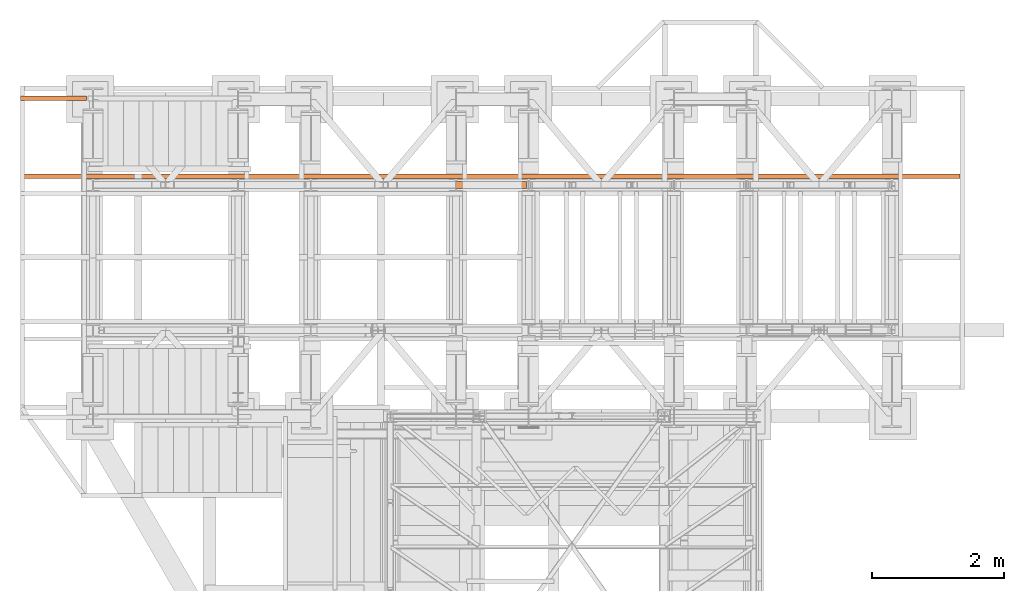
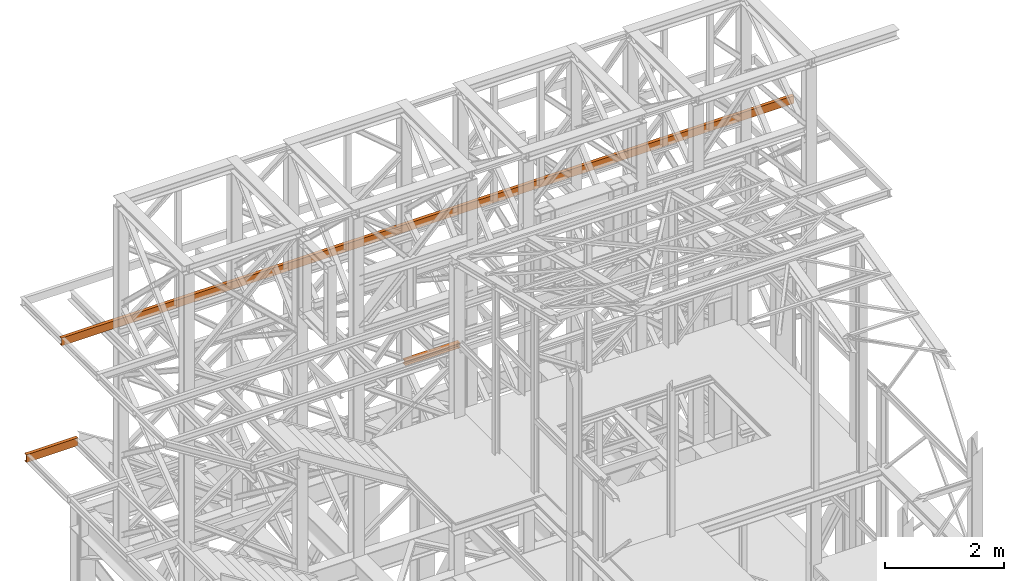
# One storey, part 131 of 208: 3 proxies.
"""IFC2X3 building model written with IfcOpenShell, lengths in millimetres."""

from ifc_helpers import new_model, entity, si_unit, converted_unit, frame, origin, origin_with_axes, place, context, subcontext, project, spatial, faceted_brep, element, save


model = new_model("IFC2X3")

# Units and contexts
model_context = context("Model", 3, precision=1e-05, world=origin())
plan_context = context("Plan", 3, precision=1e-05, world=origin())
body_context = subcontext(model_context, "Body", "Model", "MODEL_VIEW")
ifc_project = project(units=[si_unit("LENGTHUNIT", "METRE", prefix="MILLI"), converted_unit("PLANEANGLEUNIT", "DEGREE", entity("IfcPlaneAngleMeasure", 0.0174532925199433), si_unit("PLANEANGLEUNIT", "RADIAN"), dimensions=[0, 0, 0, 0, 0, 0, 0]), si_unit("AREAUNIT", "SQUARE_METRE"), si_unit("VOLUMEUNIT", "CUBIC_METRE")], contexts=[model_context, plan_context])

# Building, storey
building_placement = place(None, origin())
building = spatial("IfcBuilding", under=ifc_project, at=building_placement, CompositionType="COMPLEX")
storey_placement = place(building_placement, origin_with_axes())
storey = spatial("IfcBuildingStorey", under=building, at=storey_placement, Name="Geschoss", CompositionType="ELEMENT")

# Proxies
proxy_1_placement = place(storey_placement, frame((2191.525620187632, -13812.50587051042, 7070.668125081063), z_axis=(0.0, 0.0, 1.0), x_axis=(1.0, 0.0, 0.0)))
element("IfcBuildingElementProxy", 1, at=proxy_1_placement, inside=storey, context=body_context, shape_type="Brep", body=[
    faceted_brep([(1072.594465339767, 0.01000000000021828, 88.01000000000022), (1072.594465339767, 0.01000000000021828, 96.01000000000022), (1072.594465339767, 100.0100000000002, 96.01000000000022), (1072.594465339767, 100.0100000000002, 88.01000000000022), (1072.594465339767, 52.51000000000022, 88.01000000000022), (1072.594465339767, 52.51000000000022, 8.010000000000218), (1072.594465339767, 100.0100000000002, 8.010000000000218), (1072.594465339767, 100.0100000000002, 0.01000000000021828), (1072.594465339767, 0.01000000000021828, 0.01000000000021828), (1072.594465339767, 0.01000000000021828, 8.010000000000218), (1072.594465339767, 47.51000000000022, 8.010000000000218), (1072.594465339767, 47.51000000000022, 88.01000000000022), (1072.594465339767, 0.01000000000021828, 96.01000000000022), (1072.594465339767, 0.01000000000021828, 88.01000000000022), (0.009999999999763531, 0.01000000000385626, 88.01000000000022), (0.009999999999763531, 0.01000000000385626, 96.01000000000022), (1072.594465339767, 100.0100000000002, 96.01000000000022), (1072.594465339767, 0.01000000000021828, 96.01000000000022), (0.009999999999763531, 0.01000000000385626, 96.01000000000022), (0.009999999999763531, 100.0100000000039, 96.01000000000022), (1072.594465339767, 100.0100000000002, 88.01000000000022), (1072.594465339767, 100.0100000000002, 96.01000000000022), (0.009999999999763531, 100.0100000000039, 96.01000000000022), (0.009999999999763531, 100.0100000000039, 88.01000000000022), (1072.594465339767, 52.51000000000022, 88.01000000000022), (1072.594465339767, 100.0100000000002, 88.01000000000022), (0.009999999999763531, 100.0100000000039, 88.01000000000022), (0.009999999999763531, 52.51000000000386, 88.01000000000022), (1072.594465339767, 52.51000000000022, 8.010000000000218), (1072.594465339767, 52.51000000000022, 88.01000000000022), (0.009999999999763531, 52.51000000000386, 88.01000000000022), (0.009999999999763531, 52.51000000000386, 8.010000000000218), (1072.594465339767, 100.0100000000002, 8.010000000000218), (1072.594465339767, 52.51000000000022, 8.010000000000218), (0.009999999999763531, 52.51000000000386, 8.010000000000218), (0.009999999999763531, 100.0100000000039, 8.010000000000218), (1072.594465339767, 100.0100000000002, 0.01000000000021828), (1072.594465339767, 100.0100000000002, 8.010000000000218), (0.009999999999763531, 100.0100000000039, 8.010000000000218), (0.009999999999763531, 100.0100000000039, 0.01000000000021828), (1072.594465339767, 0.01000000000021828, 0.01000000000021828), (1072.594465339767, 100.0100000000002, 0.01000000000021828), (0.009999999999763531, 100.0100000000039, 0.01000000000021828), (0.009999999999763531, 0.01000000000385626, 0.01000000000021828), (1072.594465339767, 0.01000000000021828, 8.010000000000218), (1072.594465339767, 0.01000000000021828, 0.01000000000021828), (0.009999999999763531, 0.01000000000385626, 0.01000000000021828), (0.009999999999763531, 0.01000000000385626, 8.010000000000218), (1072.594465339767, 47.51000000000022, 8.010000000000218), (1072.594465339767, 0.01000000000021828, 8.010000000000218), (0.009999999999763531, 0.01000000000385626, 8.010000000000218), (0.009999999999763531, 47.51000000000386, 8.010000000000218), (1072.594465339767, 47.51000000000022, 88.01000000000022), (1072.594465339767, 47.51000000000022, 8.010000000000218), (0.009999999999763531, 47.51000000000386, 8.010000000000218), (0.009999999999763531, 47.51000000000386, 88.01000000000022), (1072.594465339767, 0.01000000000021828, 88.01000000000022), (1072.594465339767, 47.51000000000022, 88.01000000000022), (0.009999999999763531, 47.51000000000386, 88.01000000000022), (0.009999999999763531, 0.01000000000385626, 88.01000000000022), (0.009999999999763531, 0.01000000000385626, 88.01000000000022), (0.009999999999763531, 47.51000000000386, 88.01000000000022), (0.009999999999763531, 47.51000000000386, 8.010000000000218), (0.009999999999763531, 0.01000000000385626, 8.010000000000218), (0.009999999999763531, 0.01000000000385626, 0.01000000000021828), (0.009999999999763531, 100.0100000000039, 0.01000000000021828), (0.009999999999763531, 100.0100000000039, 8.010000000000218), (0.009999999999763531, 52.51000000000386, 8.010000000000218), (0.009999999999763531, 52.51000000000386, 88.01000000000022), (0.009999999999763531, 100.0100000000039, 88.01000000000022), (0.009999999999763531, 100.0100000000039, 96.01000000000022), (0.009999999999763531, 0.01000000000385626, 96.01000000000022)], [[[0, 1, 2, 3, 4, 5, 6, 7, 8, 9, 10, 11]], [[12, 13, 14, 15]], [[16, 17, 18, 19]], [[20, 21, 22, 23]], [[24, 25, 26, 27]], [[28, 29, 30, 31]], [[32, 33, 34, 35]], [[36, 37, 38, 39]], [[40, 41, 42, 43]], [[44, 45, 46, 47]], [[48, 49, 50, 51]], [[52, 53, 54, 55]], [[56, 57, 58, 59]], [[60, 61, 62, 63, 64, 65, 66, 67, 68, 69, 70, 71]]], orient=[[False], [False], [False], [False], [False], [False], [False], [False], [False], [False], [False], [False], [False], [False]]),
])
proxy_2_placement = place(storey_placement, frame((-4406.745032961459, -13662.57438882777, 9699.99), z_axis=(0.0, 0.0, 1.0), x_axis=(1.0, 0.0, 0.0)))
element("IfcBuildingElementProxy", 2, at=proxy_2_placement, inside=storey, context=body_context, shape_type="Brep", body=[
    faceted_brep([(0.01000000000021828, 65.01000000000022, 0.01000000000021828), (14234.76726640307, 65.01000000000022, 0.01000000000021828), (14234.76726640307, 65.01000000000022, 3.132428070246533), (0.01000000000021828, 65.01000000000022, 3.132428070246533), (0.01000000000021828, 65.01000000000022, 3.132428070246533), (14234.76726640307, 65.01000000000022, 3.132428070246533), (14234.76726640307, 64.76726342282745, 4.748288908171162), (0.01000000000021828, 64.76726342282745, 4.748288908171162), (0.01000000000021828, 64.76726342282745, 4.748288908171162), (14234.76726640307, 64.76726342282745, 4.748288908171162), (14234.76726640307, 64.06053228585552, 6.221534443444398), (0.01000000000021828, 64.06053228585733, 6.221534443444398), (0.01000000000021828, 64.06053228585733, 6.221534443444398), (14234.76726640307, 64.06053228585552, 6.221534443444398), (14234.76726640307, 62.95215163846842, 7.422126703873801), (0.01000000000021828, 62.95215163847024, 7.422126703873801), (0.01000000000021828, 62.95215163847024, 7.422126703873801), (14234.76726640307, 62.95215163846842, 7.422126703873801), (14234.76726640307, 61.53995641148504, 8.244091391710754), (0.01000000000021828, 61.53995641148686, 8.244091391710754), (0.01000000000021828, 61.53995641148686, 8.244091391710754), (14234.76726640307, 61.53995641148504, 8.244091391710754), (14234.76726640307, 59.9485987225562, 8.614912102195376), (0.01000000000021828, 59.94859872255802, 8.614912102195376), (0.01000000000021828, 59.94859872255802, 8.614912102195376), (14234.76726640307, 59.9485987225562, 8.614912102195376), (14234.76726640307, 17.17267516602988, 12.0369859867169), (0.01000000000021828, 17.17267516602988, 12.0369859867169), (0.01000000000021828, 17.17267516602988, 12.0369859867169), (14234.76726640307, 17.17267516602988, 12.0369859867169), (14234.76726640307, 14.13462866898408, 12.74491643400506), (0.01000000000021828, 14.1346286689859, 12.74491643400506), (0.01000000000021828, 14.1346286689859, 12.74491643400506), (14234.76726640307, 14.13462866898408, 12.74491643400506), (14234.76726640307, 11.43861959928654, 14.31412174714933), (0.01000000000021828, 11.43861959928836, 14.31412174714933), (0.01000000000021828, 11.43861959928836, 14.31412174714933), (14234.76726640307, 11.43861959928654, 14.31412174714933), (14234.76726640307, 9.322620181546881, 16.60616151705835), (0.01000000000021828, 9.3226201815487, 16.60616151705835), (0.01000000000021828, 9.3226201815487, 16.60616151705835), (14234.76726640307, 9.322620181546881, 16.60616151705835), (14234.76726640307, 7.97340619278657, 19.41872117530875), (0.01000000000021828, 7.97340619278657, 19.41872117530875), (0.01000000000021828, 7.97340619278657, 19.41872117530875), (14234.76726640307, 7.97340619278657, 19.41872117530875), (14234.76726640307, 7.510000000000218, 22.50354641134618), (0.01000000000021828, 7.510000000000218, 22.50354641134618), (0.01000000000021828, 7.510000000000218, 22.50354641134618), (14234.76726640307, 7.510000000000218, 22.50354641134618), (14234.76726640307, 7.510000000000218, 137.5164535886524), (0.01000000000021828, 7.510000000000218, 137.5164535886524), (0.01000000000021828, 7.510000000000218, 137.5164535886524), (14234.76726640307, 7.510000000000218, 137.5164535886524), (14234.76726640307, 7.97340619278657, 140.6012788246917), (0.01000000000021828, 7.97340619278657, 140.6012788246917), (0.01000000000021828, 7.97340619278657, 140.6012788246917), (14234.76726640307, 7.97340619278657, 140.6012788246917), (14234.76726640307, 9.322620181546881, 143.4138384829403), (0.01000000000021828, 9.3226201815487, 143.4138384829403), (0.01000000000021828, 9.3226201815487, 143.4138384829403), (14234.76726640307, 9.322620181546881, 143.4138384829403), (14234.76726640307, 11.43861959928654, 145.7058782528493), (0.01000000000021828, 11.43861959928836, 145.7058782528493), (0.01000000000021828, 11.43861959928836, 145.7058782528493), (14234.76726640307, 11.43861959928654, 145.7058782528493), (14234.76726640307, 14.13462866898408, 147.2750835659936), (0.01000000000021828, 14.1346286689859, 147.2750835659936), (0.01000000000021828, 14.1346286689859, 147.2750835659936), (14234.76726640307, 14.13462866898408, 147.2750835659936), (14234.76726640307, 17.17267516602988, 147.9830140132817), (0.01000000000021828, 17.17267516602988, 147.9830140132817), (0.01000000000021828, 17.17267516602988, 147.9830140132817), (14234.76726640307, 17.17267516602988, 147.9830140132817), (14234.76726640307, 59.9485987225562, 151.4050878978032), (0.01000000000021828, 59.94859872255802, 151.4050878978032), (0.01000000000021828, 59.94859872255802, 151.4050878978032), (14234.76726640307, 59.9485987225562, 151.4050878978032), (14234.76726640307, 61.53995641148504, 151.7759086082879), (0.01000000000021828, 61.53995641148686, 151.7759086082879), (0.01000000000021828, 61.53995641148686, 151.7759086082879), (14234.76726640307, 61.53995641148504, 151.7759086082879), (14234.76726640307, 62.95215163846842, 152.5978732961248), (0.01000000000021828, 62.95215163847024, 152.5978732961248), (0.01000000000021828, 62.95215163847024, 152.5978732961248), (14234.76726640307, 62.95215163846842, 152.5978732961248), (14234.76726640307, 64.06053228585552, 153.7984655565542), (0.01000000000021828, 64.06053228585733, 153.7984655565542), (0.01000000000021828, 64.06053228585733, 153.7984655565542), (14234.76726640307, 64.06053228585552, 153.7984655565542), (14234.76726640307, 64.76726342282745, 155.2717110918275), (0.01000000000021828, 64.76726342282745, 155.2717110918275), (0.01000000000021828, 64.76726342282745, 155.2717110918275), (14234.76726640307, 64.76726342282745, 155.2717110918275), (14234.76726640307, 65.01000000000022, 156.8875719297521), (0.01000000000021828, 65.01000000000022, 156.8875719297521), (0.01000000000021828, 65.01000000000022, 156.8875719297521), (14234.76726640307, 65.01000000000022, 156.8875719297521), (14234.76726640307, 65.01000000000022, 160.0100000000002), (0.01000000000021828, 65.01000000000022, 160.0100000000002), (0.01000000000021828, 65.01000000000022, 160.0100000000002), (14234.76726640307, 65.01000000000022, 160.0100000000002), (14234.76726640307, 0.01000000000021828, 160.0100000000002), (0.01000000000021828, 0.01000000000021828, 160.0100000000002), (0.01000000000021828, 0.01000000000021828, 160.0100000000002), (14234.76726640307, 0.01000000000021828, 160.0100000000002), (14234.76726640307, 0.01000000000021828, 0.01000000000021828), (0.01000000000021828, 0.01000000000021828, 0.01000000000021828), (0.01000000000021828, 0.01000000000021828, 0.01000000000021828), (14234.76726640307, 0.01000000000021828, 0.01000000000021828), (14234.76726640307, 65.01000000000022, 0.01000000000021828), (0.01000000000021828, 65.01000000000022, 0.01000000000021828), (0.01000000000021828, 65.01000000000022, 0.01000000000021828), (0.01000000000021828, 65.01000000000022, 3.132428070246533), (0.01000000000021828, 64.76726342282745, 4.748288908171162), (0.01000000000021828, 64.06053228585733, 6.221534443444398), (0.01000000000021828, 62.95215163847024, 7.422126703873801), (0.01000000000021828, 61.53995641148686, 8.244091391710754), (0.01000000000021828, 59.94859872255802, 8.614912102195376), (0.01000000000021828, 17.17267516602988, 12.0369859867169), (0.01000000000021828, 14.1346286689859, 12.74491643400506), (0.01000000000021828, 11.43861959928836, 14.31412174714933), (0.01000000000021828, 9.3226201815487, 16.60616151705835), (0.01000000000021828, 7.97340619278657, 19.41872117530875), (0.01000000000021828, 7.510000000000218, 22.50354641134618), (0.01000000000021828, 7.510000000000218, 137.5164535886524), (0.01000000000021828, 7.97340619278657, 140.6012788246917), (0.01000000000021828, 9.3226201815487, 143.4138384829403), (0.01000000000021828, 11.43861959928836, 145.7058782528493), (0.01000000000021828, 14.1346286689859, 147.2750835659936), (0.01000000000021828, 17.17267516602988, 147.9830140132817), (0.01000000000021828, 59.94859872255802, 151.4050878978032), (0.01000000000021828, 61.53995641148686, 151.7759086082879), (0.01000000000021828, 62.95215163847024, 152.5978732961248), (0.01000000000021828, 64.06053228585733, 153.7984655565542), (0.01000000000021828, 64.76726342282745, 155.2717110918275), (0.01000000000021828, 65.01000000000022, 156.8875719297521), (0.01000000000021828, 65.01000000000022, 160.0100000000002), (0.01000000000021828, 0.01000000000021828, 160.0100000000002), (0.01000000000021828, 0.01000000000021828, 0.01000000000021828), (14234.76726640307, 65.01000000000022, 0.01000000000021828), (14234.76726640307, 0.01000000000021828, 0.01000000000021828), (14234.76726640307, 0.01000000000021828, 160.0100000000002), (14234.76726640307, 65.01000000000022, 160.0100000000002), (14234.76726640307, 65.01000000000022, 156.8875719297521), (14234.76726640307, 64.76726342282745, 155.2717110918275), (14234.76726640307, 64.06053228585552, 153.7984655565542), (14234.76726640307, 62.95215163846842, 152.5978732961248), (14234.76726640307, 61.53995641148504, 151.7759086082879), (14234.76726640307, 59.9485987225562, 151.4050878978032), (14234.76726640307, 17.17267516602988, 147.9830140132817), (14234.76726640307, 14.13462866898408, 147.2750835659936), (14234.76726640307, 11.43861959928654, 145.7058782528493), (14234.76726640307, 9.322620181546881, 143.4138384829403), (14234.76726640307, 7.97340619278657, 140.6012788246917), (14234.76726640307, 7.510000000000218, 137.5164535886524), (14234.76726640307, 7.510000000000218, 22.50354641134618), (14234.76726640307, 7.97340619278657, 19.41872117530875), (14234.76726640307, 9.322620181546881, 16.60616151705835), (14234.76726640307, 11.43861959928654, 14.31412174714933), (14234.76726640307, 14.13462866898408, 12.74491643400506), (14234.76726640307, 17.17267516602988, 12.0369859867169), (14234.76726640307, 59.9485987225562, 8.614912102195376), (14234.76726640307, 61.53995641148504, 8.244091391710754), (14234.76726640307, 62.95215163846842, 7.422126703873801), (14234.76726640307, 64.06053228585552, 6.221534443444398), (14234.76726640307, 64.76726342282745, 4.748288908171162), (14234.76726640307, 65.01000000000022, 3.132428070246533)], [[[0, 1, 2, 3]], [[4, 5, 6, 7]], [[8, 9, 10, 11]], [[12, 13, 14, 15]], [[16, 17, 18, 19]], [[20, 21, 22, 23]], [[24, 25, 26, 27]], [[28, 29, 30, 31]], [[32, 33, 34, 35]], [[36, 37, 38, 39]], [[40, 41, 42, 43]], [[44, 45, 46, 47]], [[48, 49, 50, 51]], [[52, 53, 54, 55]], [[56, 57, 58, 59]], [[60, 61, 62, 63]], [[64, 65, 66, 67]], [[68, 69, 70, 71]], [[72, 73, 74, 75]], [[76, 77, 78, 79]], [[80, 81, 82, 83]], [[84, 85, 86, 87]], [[88, 89, 90, 91]], [[92, 93, 94, 95]], [[96, 97, 98, 99]], [[100, 101, 102, 103]], [[104, 105, 106, 107]], [[108, 109, 110, 111]], [[112, 113, 114, 115, 116, 117, 118, 119, 120, 121, 122, 123, 124, 125, 126, 127, 128, 129, 130, 131, 132, 133, 134, 135, 136, 137, 138, 139]], [[140, 141, 142, 143, 144, 145, 146, 147, 148, 149, 150, 151, 152, 153, 154, 155, 156, 157, 158, 159, 160, 161, 162, 163, 164, 165, 166, 167]]], orient=[[False], [False], [False], [False], [False], [False], [False], [False], [False], [False], [False], [False], [False], [False], [False], [False], [False], [False], [False], [False], [False], [False], [False], [False], [False], [False], [False], [False], [False], [False]]),
])
proxy_3_placement = place(storey_placement, frame((-4406.745032961459, -12479.73706227429, 6584.990005364416), z_axis=(0.0, 0.0, 1.0), x_axis=(1.0, 0.0, 0.0)))
element("IfcBuildingElementProxy", 3, at=proxy_3_placement, inside=storey, context=body_context, shape_type="Brep", body=[
    faceted_brep([(0.01000000000021828, 65.01000000000022, 0.01000000000021828), (1000.010000000006, 65.01000000000204, 0.01000000000021828), (1000.010000000006, 65.01000000000204, 3.132428070246533), (0.01000000000021828, 65.01000000000022, 3.132428070246533), (0.01000000000021828, 65.01000000000022, 3.132428070246533), (1000.010000000006, 65.01000000000204, 3.132428070246533), (1000.010000000006, 64.76726342282745, 4.748288908171162), (0.01000000000021828, 64.76726342282745, 4.748288908171162), (0.01000000000021828, 64.76726342282745, 4.748288908171162), (1000.010000000006, 64.76726342282745, 4.748288908171162), (1000.010000000006, 64.06053228585915, 6.221534443444398), (0.01000000000021828, 64.06053228585733, 6.221534443444398), (0.01000000000021828, 64.06053228585733, 6.221534443444398), (1000.010000000006, 64.06053228585915, 6.221534443444398), (1000.010000000006, 62.95215163847206, 7.422126703873801), (0.01000000000021828, 62.95215163847024, 7.422126703873801), (0.01000000000021828, 62.95215163847024, 7.422126703873801), (1000.010000000006, 62.95215163847206, 7.422126703873801), (1000.010000000006, 61.53995641148686, 8.244091391710754), (0.01000000000021828, 61.53995641148686, 8.244091391710754), (0.01000000000021828, 61.53995641148686, 8.244091391710754), (1000.010000000006, 61.53995641148686, 8.244091391710754), (1000.010000000006, 59.94859872255802, 8.614912102195376), (0.01000000000021828, 59.94859872255802, 8.614912102195376), (0.01000000000021828, 59.94859872255802, 8.614912102195376), (1000.010000000006, 59.94859872255802, 8.614912102195376), (1000.010000000006, 17.1726751660317, 12.0369859867169), (0.01000000000021828, 17.17267516602988, 12.0369859867169), (0.01000000000021828, 17.17267516602988, 12.0369859867169), (1000.010000000006, 17.1726751660317, 12.0369859867169), (1000.010000000006, 14.1346286689859, 12.74491643400506), (0.01000000000021828, 14.1346286689859, 12.74491643400506), (0.01000000000021828, 14.1346286689859, 12.74491643400506), (1000.010000000006, 14.1346286689859, 12.74491643400506), (1000.010000000006, 11.43861959928836, 14.31412174714933), (0.01000000000021828, 11.43861959928836, 14.31412174714933), (0.01000000000021828, 11.43861959928836, 14.31412174714933), (1000.010000000006, 11.43861959928836, 14.31412174714933), (1000.010000000006, 9.3226201815487, 16.60616151705835), (0.01000000000021828, 9.3226201815487, 16.60616151705835), (0.01000000000021828, 9.3226201815487, 16.60616151705835), (1000.010000000006, 9.3226201815487, 16.60616151705835), (1000.010000000006, 7.973406192788389, 19.41872117530875), (0.01000000000021828, 7.97340619278657, 19.41872117530875), (0.01000000000021828, 7.97340619278657, 19.41872117530875), (1000.010000000006, 7.973406192788389, 19.41872117530875), (1000.010000000006, 7.510000000002037, 22.50354641134618), (0.01000000000021828, 7.510000000000218, 22.50354641134618), (0.01000000000021828, 7.510000000000218, 22.50354641134618), (1000.010000000006, 7.510000000002037, 22.50354641134618), (1000.010000000006, 7.510000000002037, 137.5164535886524), (0.01000000000021828, 7.510000000000218, 137.5164535886524), (0.01000000000021828, 7.510000000000218, 137.5164535886524), (1000.010000000006, 7.510000000002037, 137.5164535886524), (1000.010000000006, 7.973406192788389, 140.6012788246917), (0.01000000000021828, 7.97340619278657, 140.6012788246917), (0.01000000000021828, 7.97340619278657, 140.6012788246917), (1000.010000000006, 7.973406192788389, 140.6012788246917), (1000.010000000006, 9.3226201815487, 143.4138384829403), (0.01000000000021828, 9.3226201815487, 143.4138384829403), (0.01000000000021828, 9.3226201815487, 143.4138384829403), (1000.010000000006, 9.3226201815487, 143.4138384829403), (1000.010000000006, 11.43861959928836, 145.7058782528493), (0.01000000000021828, 11.43861959928836, 145.7058782528493), (0.01000000000021828, 11.43861959928836, 145.7058782528493), (1000.010000000006, 11.43861959928836, 145.7058782528493), (1000.010000000006, 14.1346286689859, 147.2750835659936), (0.01000000000021828, 14.1346286689859, 147.2750835659936), (0.01000000000021828, 14.1346286689859, 147.2750835659936), (1000.010000000006, 14.1346286689859, 147.2750835659936), (1000.010000000006, 17.1726751660317, 147.9830140132817), (0.01000000000021828, 17.17267516602988, 147.9830140132817), (0.01000000000021828, 17.17267516602988, 147.9830140132817), (1000.010000000006, 17.1726751660317, 147.9830140132817), (1000.010000000006, 59.94859872255802, 151.4050878978032), (0.01000000000021828, 59.94859872255802, 151.4050878978032), (0.01000000000021828, 59.94859872255802, 151.4050878978032), (1000.010000000006, 59.94859872255802, 151.4050878978032), (1000.010000000006, 61.53995641148686, 151.7759086082879), (0.01000000000021828, 61.53995641148686, 151.7759086082879), (0.01000000000021828, 61.53995641148686, 151.7759086082879), (1000.010000000006, 61.53995641148686, 151.7759086082879), (1000.010000000006, 62.95215163847206, 152.5978732961248), (0.01000000000021828, 62.95215163847024, 152.5978732961248), (0.01000000000021828, 62.95215163847024, 152.5978732961248), (1000.010000000006, 62.95215163847206, 152.5978732961248), (1000.010000000006, 64.06053228585915, 153.7984655565542), (0.01000000000021828, 64.06053228585733, 153.7984655565542), (0.01000000000021828, 64.06053228585733, 153.7984655565542), (1000.010000000006, 64.06053228585915, 153.7984655565542), (1000.010000000006, 64.76726342282745, 155.2717110918275), (0.01000000000021828, 64.76726342282745, 155.2717110918275), (0.01000000000021828, 64.76726342282745, 155.2717110918275), (1000.010000000006, 64.76726342282745, 155.2717110918275), (1000.010000000006, 65.01000000000204, 156.8875719297521), (0.01000000000021828, 65.01000000000022, 156.8875719297521), (0.01000000000021828, 65.01000000000022, 156.8875719297521), (1000.010000000006, 65.01000000000204, 156.8875719297521), (1000.010000000006, 65.01000000000204, 160.0100000000002), (0.01000000000021828, 65.01000000000022, 160.0100000000002), (0.01000000000021828, 65.01000000000022, 160.0100000000002), (1000.010000000006, 65.01000000000204, 160.0100000000002), (1000.010000000006, 0.01000000000203727, 160.0100000000002), (0.01000000000021828, 0.01000000000021828, 160.0100000000002), (0.01000000000021828, 0.01000000000021828, 160.0100000000002), (1000.010000000006, 0.01000000000203727, 160.0100000000002), (1000.010000000006, 0.01000000000203727, 0.01000000000021828), (0.01000000000021828, 0.01000000000021828, 0.01000000000021828), (0.01000000000021828, 0.01000000000021828, 0.01000000000021828), (1000.010000000006, 0.01000000000203727, 0.01000000000021828), (1000.010000000006, 65.01000000000204, 0.01000000000021828), (0.01000000000021828, 65.01000000000022, 0.01000000000021828), (0.01000000000021828, 65.01000000000022, 0.01000000000021828), (0.01000000000021828, 65.01000000000022, 3.132428070246533), (0.01000000000021828, 64.76726342282745, 4.748288908171162), (0.01000000000021828, 64.06053228585733, 6.221534443444398), (0.01000000000021828, 62.95215163847024, 7.422126703873801), (0.01000000000021828, 61.53995641148686, 8.244091391710754), (0.01000000000021828, 59.94859872255802, 8.614912102195376), (0.01000000000021828, 17.17267516602988, 12.0369859867169), (0.01000000000021828, 14.1346286689859, 12.74491643400506), (0.01000000000021828, 11.43861959928836, 14.31412174714933), (0.01000000000021828, 9.3226201815487, 16.60616151705835), (0.01000000000021828, 7.97340619278657, 19.41872117530875), (0.01000000000021828, 7.510000000000218, 22.50354641134618), (0.01000000000021828, 7.510000000000218, 137.5164535886524), (0.01000000000021828, 7.97340619278657, 140.6012788246917), (0.01000000000021828, 9.3226201815487, 143.4138384829403), (0.01000000000021828, 11.43861959928836, 145.7058782528493), (0.01000000000021828, 14.1346286689859, 147.2750835659936), (0.01000000000021828, 17.17267516602988, 147.9830140132817), (0.01000000000021828, 59.94859872255802, 151.4050878978032), (0.01000000000021828, 61.53995641148686, 151.7759086082879), (0.01000000000021828, 62.95215163847024, 152.5978732961248), (0.01000000000021828, 64.06053228585733, 153.7984655565542), (0.01000000000021828, 64.76726342282745, 155.2717110918275), (0.01000000000021828, 65.01000000000022, 156.8875719297521), (0.01000000000021828, 65.01000000000022, 160.0100000000002), (0.01000000000021828, 0.01000000000021828, 160.0100000000002), (0.01000000000021828, 0.01000000000021828, 0.01000000000021828), (1000.010000000006, 65.01000000000204, 0.01000000000021828), (1000.010000000006, 0.01000000000203727, 0.01000000000021828), (1000.010000000006, 0.01000000000203727, 160.0100000000002), (1000.010000000006, 65.01000000000204, 160.0100000000002), (1000.010000000006, 65.01000000000204, 156.8875719297521), (1000.010000000006, 64.76726342282745, 155.2717110918275), (1000.010000000006, 64.06053228585915, 153.7984655565542), (1000.010000000006, 62.95215163847206, 152.5978732961248), (1000.010000000006, 61.53995641148686, 151.7759086082879), (1000.010000000006, 59.94859872255802, 151.4050878978032), (1000.010000000006, 17.1726751660317, 147.9830140132817), (1000.010000000006, 14.1346286689859, 147.2750835659936), (1000.010000000006, 11.43861959928836, 145.7058782528493), (1000.010000000006, 9.3226201815487, 143.4138384829403), (1000.010000000006, 7.973406192788389, 140.6012788246917), (1000.010000000006, 7.510000000002037, 137.5164535886524), (1000.010000000006, 7.510000000002037, 22.50354641134618), (1000.010000000006, 7.973406192788389, 19.41872117530875), (1000.010000000006, 9.3226201815487, 16.60616151705835), (1000.010000000006, 11.43861959928836, 14.31412174714933), (1000.010000000006, 14.1346286689859, 12.74491643400506), (1000.010000000006, 17.1726751660317, 12.0369859867169), (1000.010000000006, 59.94859872255802, 8.614912102195376), (1000.010000000006, 61.53995641148686, 8.244091391710754), (1000.010000000006, 62.95215163847206, 7.422126703873801), (1000.010000000006, 64.06053228585915, 6.221534443444398), (1000.010000000006, 64.76726342282745, 4.748288908171162), (1000.010000000006, 65.01000000000204, 3.132428070246533)], [[[0, 1, 2, 3]], [[4, 5, 6, 7]], [[8, 9, 10, 11]], [[12, 13, 14, 15]], [[16, 17, 18, 19]], [[20, 21, 22, 23]], [[24, 25, 26, 27]], [[28, 29, 30, 31]], [[32, 33, 34, 35]], [[36, 37, 38, 39]], [[40, 41, 42, 43]], [[44, 45, 46, 47]], [[48, 49, 50, 51]], [[52, 53, 54, 55]], [[56, 57, 58, 59]], [[60, 61, 62, 63]], [[64, 65, 66, 67]], [[68, 69, 70, 71]], [[72, 73, 74, 75]], [[76, 77, 78, 79]], [[80, 81, 82, 83]], [[84, 85, 86, 87]], [[88, 89, 90, 91]], [[92, 93, 94, 95]], [[96, 97, 98, 99]], [[100, 101, 102, 103]], [[104, 105, 106, 107]], [[108, 109, 110, 111]], [[112, 113, 114, 115, 116, 117, 118, 119, 120, 121, 122, 123, 124, 125, 126, 127, 128, 129, 130, 131, 132, 133, 134, 135, 136, 137, 138, 139]], [[140, 141, 142, 143, 144, 145, 146, 147, 148, 149, 150, 151, 152, 153, 154, 155, 156, 157, 158, 159, 160, 161, 162, 163, 164, 165, 166, 167]]], orient=[[False], [False], [False], [False], [False], [False], [False], [False], [False], [False], [False], [False], [False], [False], [False], [False], [False], [False], [False], [False], [False], [False], [False], [False], [False], [False], [False], [False], [False], [False]]),
])

save(model, "model.ifc")
